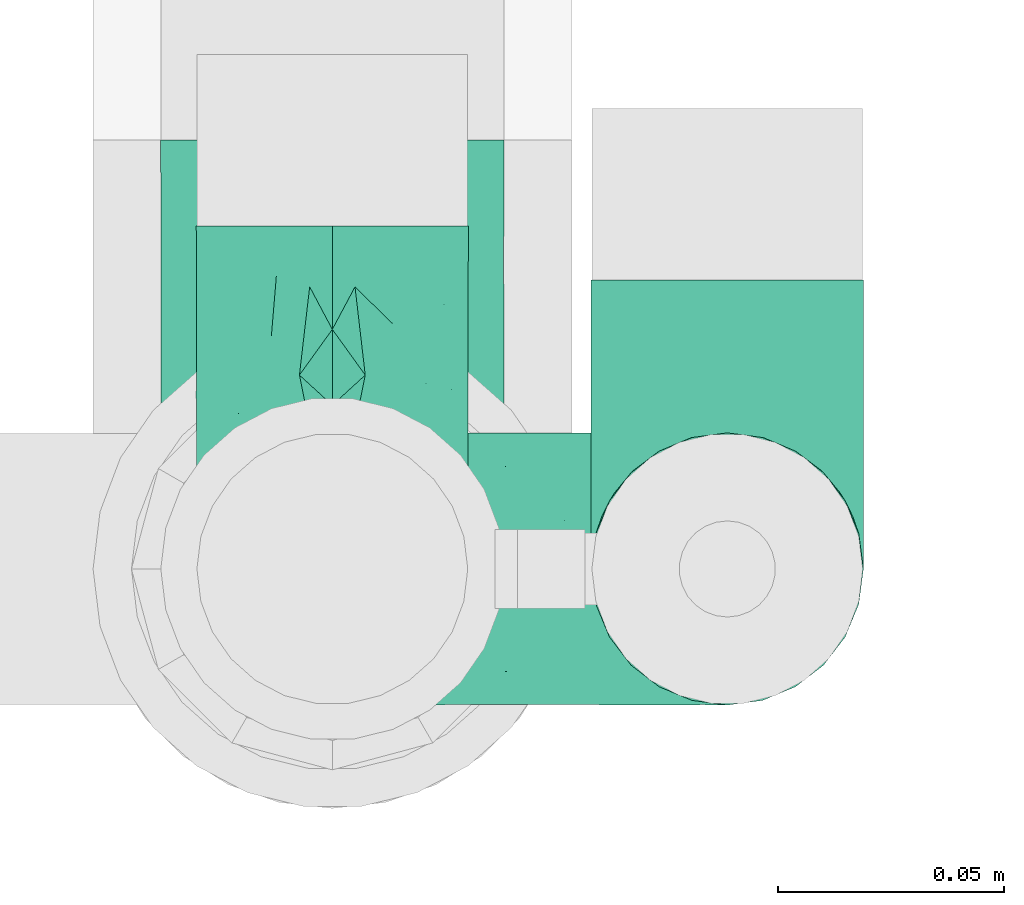
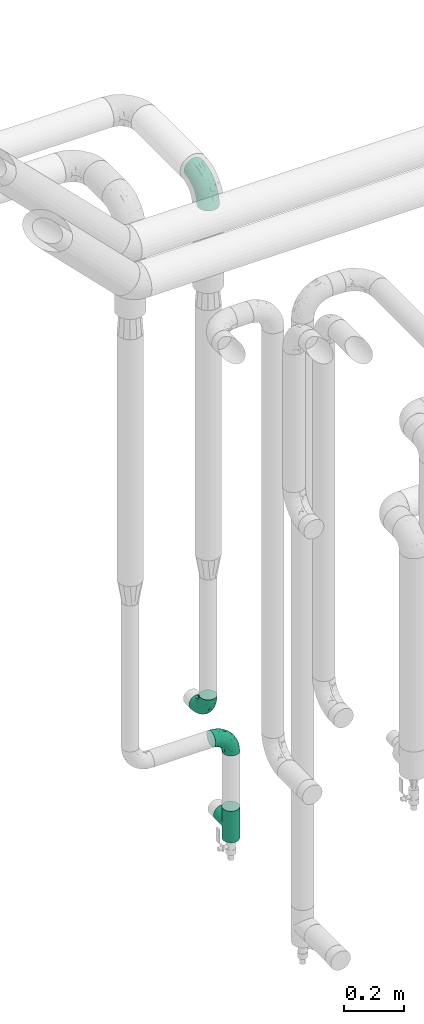
# One storey, part 682 of 824: 4 flow fittings.
"""IFC2X3 building model written with IfcOpenShell, lengths in millimetres."""

from ifc_helpers import new_model, entity, si_unit, converted_unit, derived_unit, direction, frame, origin, place, context, subcontext, project, spatial, faceted_brep, source, transform, mapped, material, type_object, type_shapes, element, save


model = new_model("IFC2X3")

# Units and contexts
model_context = context("Model", 3, precision=0.01, world=origin(), true_north=direction((6.12303176911189e-17, 1.0)))
body_context = subcontext(model_context, "Body", "Model", "MODEL_VIEW")
ifc_project = project(units=[si_unit("LENGTHUNIT", "METRE", prefix="MILLI"), si_unit("AREAUNIT", "SQUARE_METRE"), si_unit("VOLUMEUNIT", "CUBIC_METRE"), converted_unit("PLANEANGLEUNIT", "DEGREE", entity("IfcRatioMeasure", 0.0174532925199433), si_unit("PLANEANGLEUNIT", "RADIAN"), dimensions=[0, 0, 0, 0, 0, 0, 0]), si_unit("MASSUNIT", "GRAM", prefix="KILO"), derived_unit("MASSDENSITYUNIT", [(si_unit("MASSUNIT", "GRAM", prefix="KILO"), 1), (si_unit("LENGTHUNIT", "METRE"), -3)]), derived_unit("MOMENTOFINERTIAUNIT", [(si_unit("LENGTHUNIT", "METRE"), 4)]), si_unit("TIMEUNIT", "SECOND"), si_unit("FREQUENCYUNIT", "HERTZ"), si_unit("THERMODYNAMICTEMPERATUREUNIT", "DEGREE_CELSIUS"), derived_unit("THERMALTRANSMITTANCEUNIT", [(si_unit("MASSUNIT", "GRAM", prefix="KILO"), 1), (si_unit("THERMODYNAMICTEMPERATUREUNIT", "KELVIN"), -1), (si_unit("TIMEUNIT", "SECOND"), -3)]), derived_unit("VOLUMETRICFLOWRATEUNIT", [(si_unit("LENGTHUNIT", "METRE"), 3), (si_unit("TIMEUNIT", "SECOND"), -1)]), derived_unit("MASSFLOWRATEUNIT", [(si_unit("MASSUNIT", "GRAM", prefix="KILO"), 1), (si_unit("TIMEUNIT", "SECOND"), -1)]), derived_unit("ROTATIONALFREQUENCYUNIT", [(si_unit("TIMEUNIT", "SECOND"), -1)]), si_unit("ELECTRICCURRENTUNIT", "AMPERE"), si_unit("ELECTRICVOLTAGEUNIT", "VOLT"), si_unit("POWERUNIT", "WATT"), si_unit("FORCEUNIT", "NEWTON", prefix="KILO"), si_unit("ILLUMINANCEUNIT", "LUX"), si_unit("LUMINOUSFLUXUNIT", "LUMEN"), si_unit("LUMINOUSINTENSITYUNIT", "CANDELA"), derived_unit("USERDEFINED", [(si_unit("MASSUNIT", "GRAM", prefix="KILO"), -1), (si_unit("LENGTHUNIT", "METRE"), -2), (si_unit("TIMEUNIT", "SECOND"), 3), (si_unit("LUMINOUSFLUXUNIT", "LUMEN"), 1)]), derived_unit("LINEARVELOCITYUNIT", [(si_unit("LENGTHUNIT", "METRE"), 1), (si_unit("TIMEUNIT", "SECOND"), -1)]), si_unit("PRESSUREUNIT", "PASCAL"), derived_unit("USERDEFINED", [(si_unit("LENGTHUNIT", "METRE"), -2), (si_unit("MASSUNIT", "GRAM", prefix="KILO"), 1), (si_unit("TIMEUNIT", "SECOND"), -2)]), derived_unit("LINEARFORCEUNIT", [(si_unit("MASSUNIT", "GRAM", prefix="KILO"), 1), (si_unit("LENGTHUNIT", "METRE"), 1), (si_unit("TIMEUNIT", "SECOND"), -2), (si_unit("LENGTHUNIT", "METRE"), -1)]), derived_unit("PLANARFORCEUNIT", [(si_unit("MASSUNIT", "GRAM", prefix="KILO"), 1), (si_unit("LENGTHUNIT", "METRE"), 1), (si_unit("TIMEUNIT", "SECOND"), -2), (si_unit("LENGTHUNIT", "METRE"), -2)])], contexts=[model_context])

# Site, building, storey
site_placement = place(None, origin())
site = spatial("IfcSite", under=ifc_project, at=site_placement, CompositionType="ELEMENT")
building_placement = place(site_placement, origin())
building = spatial("IfcBuilding", under=site, at=building_placement, CompositionType="ELEMENT")
storey_placement = place(building_placement, frame((0.0, 0.0, 28200.0)))
storey = spatial("IfcBuildingStorey", under=building, at=storey_placement, CompositionType="ELEMENT", Elevation=28200.0)

# Flow fittings
ifc_material = material()
pipe_fitting_type_1 = type_object("IfcPipeFittingType", PredefinedType="NOTDEFINED", material=ifc_material)
shared_shape_1 = source(origin(), body_context, "Body", "Brep", [
    faceted_brep([(-76.0, 15.07, -26.11), (-76.0, 7.8, -29.12), (-76.0, 0.0, -30.15), (-76.0, -7.8, -29.12), (-76.0, -15.08, -26.11), (-76.0, -21.32, -21.32), (-76.0, -26.11, -15.08), (-76.0, -29.12, -7.8), (-76.0, -30.15, 0.0), (-76.0, -29.12, 7.8), (-76.0, -26.11, 15.07), (-76.0, -21.32, 21.32), (-76.0, -15.08, 26.11), (-76.0, -7.8, 29.12), (-76.0, 0.0, 30.15), (-76.0, 7.8, 29.12), (-76.0, 15.07, 26.11), (-76.0, 21.32, 21.32), (-76.0, 26.11, 15.07), (-76.0, 29.12, 7.8), (-76.0, 30.15, 0.0), (-76.0, 29.12, -7.8), (-76.0, 26.11, -15.08), (-76.0, 21.32, -21.32), (0.0, 76.0, -30.15), (-7.8, 76.0, -29.12), (-15.07, 76.0, -26.11), (-21.32, 76.0, -21.32), (-26.11, 76.0, -15.08), (-29.12, 76.0, -7.8), (-30.15, 76.0, 0.0), (-29.12, 76.0, 7.8), (-26.11, 76.0, 15.07), (-21.32, 76.0, 21.32), (-15.07, 76.0, 26.11), (-7.8, 76.0, 29.12), (0.0, 76.0, 30.15), (7.8, 76.0, 29.12), (15.08, 76.0, 26.11), (21.32, 76.0, 21.32), (26.11, 76.0, 15.07), (29.12, 76.0, 7.8), (30.15, 76.0, 0.0), (29.12, 76.0, -7.8), (26.11, 76.0, -15.08), (21.32, 76.0, -21.32), (15.08, 76.0, -26.11), (7.8, 76.0, -29.12), (10.79, 31.43, 21.07), (4.32, 31.7, 25.72), (1.65, 15.19, 19.92), (-61.17, -27.8, 0.0), (-51.1, -25.49, 9.84), (-56.14, -10.61, 27.27), (-31.7, -4.32, 25.72), (-39.75, 1.72, 29.41), (-43.2, -24.95, 0.0), (-1.86, 1.86, 0.0), (4.49, 7.65, 5.78), (-7.82, -4.61, 5.83), (-56.21, -22.79, 17.21), (-58.98, -3.38, 29.7), (-53.96, 5.6, 30.07), (-10.86, 10.86, 25.48), (-17.2, -2.6, 20.44), (-49.15, -16.01, 22.7), (-22.18, -14.24, 7.99), (-28.4, -17.42, 0.0), (-13.61, -9.88, 0.0), (-39.0, 23.48, 27.76), (-58.76, 12.54, 28.36), (-41.61, 15.41, 29.48), (16.01, 49.15, 22.7), (-58.55, 25.93, 19.53), (-51.53, 33.5, 13.51), (-64.92, 28.76, 12.4), (-7.48, 23.14, 28.25), (-1.72, 39.75, 29.41), (-12.04, 27.88, 29.88), (-63.91, 18.81, 24.52), (-11.63, 65.16, 28.18), (-4.97, 57.02, 30.05), (9.88, 13.61, 0.0), (-62.5, 31.74, 5.02), (-45.17, 30.98, 21.2), (-21.78, 9.76, 28.58), (10.61, 56.14, 27.27), (-32.09, 54.42, 13.26), (22.79, 56.21, 17.21), (15.38, 31.17, 15.63), (25.49, 51.1, 9.84), (21.84, 36.35, 5.92), (24.95, 43.2, 0.0), (3.38, 58.98, 29.7), (-31.17, -15.38, 15.63), (-39.39, 41.78, 15.45), (-34.56, 41.13, 20.79), (-39.81, -23.25, 5.49), (27.8, 61.17, 0.0), (-31.74, 62.5, 5.02), (-53.07, 36.29, 0.0), (-42.95, 42.95, 7.29), (-36.29, 53.07, 0.0), (-19.83, 58.51, 24.79), (-25.48, 60.2, 19.41), (-14.53, 50.96, 28.57), (-13.31, 37.09, 30.07), (-26.16, 40.06, 26.4), (-32.43, -10.35, 21.9), (17.42, 28.4, 0.0), (14.24, 22.18, 7.99), (-38.67, 9.72, 30.15), (-24.66, 17.36, 30.09), (-37.08, 31.49, 24.99), (-49.27, 22.83, 25.24), (-20.8, 38.81, 28.63), (-27.58, 27.58, 29.2), (-36.07, -20.23, 10.71), (-15.19, -6.16, 14.9), (6.6, 15.4, 14.49), (-2.51, 2.51, 11.35), (-65.16, 11.63, -28.18), (-49.15, -16.01, -22.7), (-57.02, 4.97, -30.05), (-25.93, 58.55, -19.53), (-33.5, 51.53, -13.51), (-28.76, 64.92, -12.4), (-60.2, 25.48, -19.41), (-58.51, 19.83, -24.79), (4.61, 7.82, -5.83), (-7.65, -4.49, -5.78), (-2.51, 2.51, -11.35), (-62.5, 31.74, -5.02), (-50.96, 14.53, -28.57), (-37.09, 13.31, -30.07), (-42.95, 42.95, -7.29), (25.49, 51.1, -9.84), (22.79, 56.21, -17.21), (-40.06, 26.16, -26.4), (3.38, 58.98, -29.7), (-5.6, 53.96, -30.07), (-27.88, 12.04, -29.88), (-9.76, 21.78, -28.58), (-23.14, 7.48, -28.25), (-51.1, -25.49, -9.84), (15.38, 31.17, -15.63), (16.01, 49.15, -22.7), (-23.48, 39.0, -27.76), (-12.54, 58.76, -28.36), (-15.41, 41.61, -29.48), (-56.21, -22.79, -17.21), (-9.72, 38.67, -30.15), (-17.36, 24.66, -30.09), (-22.18, -14.24, -7.99), (-41.13, 34.56, -20.79), (-31.74, 62.5, -5.02), (-58.98, -3.38, -29.7), (-31.17, -15.38, -15.63), (-56.14, -10.61, -27.27), (14.24, 22.18, -7.99), (23.25, 39.81, -5.49), (-31.49, 37.08, -24.99), (-15.19, -6.16, -14.9), (1.65, 15.19, -19.92), (-18.81, 63.91, -24.52), (-32.59, -11.62, -20.84), (-31.7, -4.32, -25.72), (-17.2, -2.6, -20.44), (-39.75, 1.72, -29.41), (-54.42, 32.09, -13.26), (-30.98, 45.17, -21.2), (10.61, 56.14, -27.27), (10.23, 31.31, -21.52), (4.32, 31.7, -25.72), (-41.78, 39.39, -15.45), (-1.72, 39.75, -29.41), (-36.35, -21.84, -5.92), (-22.83, 49.27, -25.24), (-38.81, 20.8, -28.63), (-27.58, 27.58, -29.2), (-10.86, 10.86, -25.48), (20.23, 36.07, -10.71), (6.6, 15.4, -14.49)], [[[0, 1, 2, 3, 4, 5, 6, 7, 8, 9, 10, 11, 12, 13, 14, 15, 16, 17, 18, 19, 20, 21, 22, 23]], [[24, 25, 26, 27, 28, 29, 30, 31, 32, 33, 34, 35, 36, 37, 38, 39, 40, 41, 42, 43, 44, 45, 46, 47]], [[48, 49, 50]], [[51, 52, 9]], [[53, 54, 55]], [[9, 52, 10]], [[56, 52, 51]], [[57, 58, 59]], [[11, 10, 60]], [[14, 61, 62]], [[63, 54, 64]], [[65, 12, 11]], [[65, 53, 12]], [[66, 67, 68]], [[69, 70, 71]], [[72, 39, 38]], [[73, 74, 75]], [[15, 70, 16]], [[76, 77, 78]], [[16, 79, 17]], [[13, 61, 14]], [[35, 80, 81]], [[14, 62, 15]], [[17, 73, 18]], [[57, 82, 58]], [[20, 19, 83]], [[75, 19, 18]], [[70, 15, 62]], [[73, 84, 74]], [[78, 85, 76]], [[38, 86, 72]], [[32, 31, 87]], [[88, 89, 90]], [[91, 92, 90]], [[72, 86, 49]], [[36, 93, 37]], [[75, 83, 19]], [[36, 35, 81]], [[60, 94, 65]], [[40, 90, 41]], [[95, 96, 87]], [[88, 90, 40]], [[66, 97, 67]], [[90, 98, 41]], [[40, 39, 88]], [[99, 31, 30]], [[20, 83, 100]], [[101, 102, 100]], [[52, 60, 10]], [[102, 99, 30]], [[96, 103, 104]], [[83, 101, 100]], [[12, 53, 13]], [[104, 103, 33]], [[105, 106, 81]], [[107, 105, 103]], [[64, 54, 108]], [[80, 103, 105]], [[80, 35, 34]], [[34, 33, 103]], [[86, 38, 37]], [[109, 110, 82]], [[71, 111, 112]], [[69, 107, 113]], [[79, 73, 17]], [[114, 113, 84]], [[33, 32, 104]], [[115, 107, 116]], [[105, 115, 106]], [[93, 81, 77]], [[54, 53, 65]], [[61, 53, 55]], [[108, 94, 64]], [[54, 63, 85]], [[93, 86, 37]], [[77, 76, 49]], [[77, 49, 86]], [[49, 63, 50]], [[60, 52, 117]], [[65, 11, 60]], [[39, 72, 88]], [[89, 88, 72]], [[71, 70, 62]], [[79, 70, 114]], [[103, 96, 107]], [[69, 113, 114]], [[112, 106, 116]], [[77, 81, 106]], [[112, 116, 71]], [[112, 55, 85]], [[64, 50, 63]], [[57, 59, 68]], [[32, 87, 104]], [[96, 104, 87]], [[94, 118, 64]], [[50, 119, 89]], [[50, 64, 118]], [[50, 89, 48]], [[81, 93, 36]], [[86, 93, 77]], [[53, 61, 13]], [[62, 61, 55]], [[71, 62, 111]], [[69, 71, 116]], [[95, 101, 74]], [[99, 101, 87]], [[118, 66, 59]], [[117, 97, 66]], [[117, 66, 94]], [[91, 89, 110]], [[91, 110, 109]], [[110, 89, 119]], [[9, 8, 51]], [[98, 90, 92]], [[98, 42, 41]], [[101, 83, 74]], [[101, 99, 102]], [[87, 31, 99]], [[62, 55, 111]], [[55, 112, 111]], [[107, 69, 116]], [[70, 69, 114]], [[107, 96, 113]], [[84, 113, 96]], [[84, 96, 95]], [[114, 84, 73]], [[70, 79, 16]], [[73, 79, 114]], [[54, 85, 55]], [[76, 85, 63]], [[49, 76, 63]], [[77, 106, 78]], [[106, 112, 78]], [[85, 78, 112]], [[73, 75, 18]], [[83, 75, 74]], [[103, 80, 34]], [[81, 80, 105]], [[101, 95, 87]], [[84, 95, 74]], [[106, 115, 116]], [[105, 107, 115]], [[120, 59, 58]], [[82, 110, 58]], [[119, 58, 110]], [[118, 59, 120]], [[66, 68, 59]], [[54, 65, 108]], [[94, 108, 65]], [[66, 118, 94]], [[50, 118, 120]], [[50, 120, 119]], [[119, 120, 58]], [[89, 72, 48]], [[49, 48, 72]], [[60, 117, 94]], [[117, 52, 97]], [[52, 56, 97]], [[67, 97, 56]], [[92, 91, 109]], [[89, 91, 90]], [[121, 1, 0]], [[122, 5, 4]], [[2, 1, 123]], [[124, 125, 126]], [[127, 128, 23]], [[129, 130, 131]], [[100, 132, 20]], [[133, 134, 123]], [[135, 100, 102]], [[136, 137, 44]], [[133, 128, 138]], [[24, 139, 140]], [[141, 142, 143]], [[121, 128, 133]], [[6, 144, 7]], [[137, 145, 146]], [[144, 51, 7]], [[147, 148, 149]], [[144, 6, 150]], [[149, 151, 152]], [[153, 68, 67]], [[154, 128, 127]], [[30, 155, 102]], [[43, 42, 98]], [[156, 3, 2]], [[157, 144, 150]], [[158, 4, 3]], [[24, 140, 25]], [[155, 135, 102]], [[159, 160, 109]], [[30, 29, 155]], [[147, 138, 161]], [[27, 124, 28]], [[57, 129, 82]], [[162, 163, 131]], [[27, 26, 164]], [[148, 26, 25]], [[165, 166, 167]], [[24, 47, 139]], [[143, 168, 141]], [[22, 21, 169]], [[125, 124, 170]], [[148, 25, 140]], [[46, 146, 171]], [[158, 122, 4]], [[0, 23, 128]], [[1, 121, 123]], [[109, 82, 159]], [[45, 44, 137]], [[146, 46, 45]], [[136, 43, 98]], [[132, 21, 20]], [[136, 98, 92]], [[172, 173, 146]], [[46, 171, 47]], [[43, 136, 44]], [[174, 154, 169]], [[171, 173, 175]], [[6, 5, 150]], [[126, 29, 28]], [[176, 56, 144]], [[122, 158, 166]], [[164, 124, 27]], [[177, 161, 170]], [[23, 22, 127]], [[178, 138, 179]], [[133, 178, 134]], [[156, 123, 168]], [[156, 158, 3]], [[168, 143, 166]], [[168, 166, 158]], [[166, 180, 167]], [[173, 171, 146]], [[139, 171, 175]], [[172, 145, 163]], [[173, 180, 142]], [[5, 122, 150]], [[157, 150, 122]], [[137, 136, 181]], [[146, 45, 137]], [[149, 148, 140]], [[164, 148, 177]], [[128, 154, 138]], [[147, 161, 177]], [[152, 134, 179]], [[168, 123, 134]], [[152, 179, 149]], [[152, 175, 142]], [[57, 130, 129]], [[157, 165, 167]], [[22, 169, 127]], [[154, 127, 169]], [[163, 167, 180]], [[162, 157, 167]], [[173, 163, 180]], [[182, 163, 145]], [[123, 156, 2]], [[158, 156, 168]], [[171, 139, 47]], [[140, 139, 175]], [[149, 140, 151]], [[147, 149, 179]], [[174, 135, 125]], [[132, 135, 169]], [[176, 157, 153]], [[176, 153, 67]], [[153, 157, 162]], [[182, 159, 129]], [[181, 160, 159]], [[181, 159, 145]], [[51, 144, 56]], [[51, 8, 7]], [[135, 132, 100]], [[169, 21, 132]], [[126, 155, 29]], [[135, 155, 125]], [[140, 175, 151]], [[175, 152, 151]], [[138, 147, 179]], [[148, 147, 177]], [[138, 154, 161]], [[170, 161, 154]], [[170, 154, 174]], [[177, 170, 124]], [[148, 164, 26]], [[124, 164, 177]], [[173, 142, 175]], [[143, 142, 180]], [[166, 143, 180]], [[168, 134, 141]], [[134, 152, 141]], [[142, 141, 152]], [[124, 126, 28]], [[155, 126, 125]], [[128, 121, 0]], [[123, 121, 133]], [[135, 174, 169]], [[170, 174, 125]], [[134, 178, 179]], [[133, 138, 178]], [[130, 153, 162]], [[68, 153, 130]], [[57, 68, 130]], [[182, 129, 131]], [[159, 82, 129]], [[157, 122, 165]], [[166, 165, 122]], [[163, 162, 167]], [[162, 131, 130]], [[145, 172, 146]], [[163, 173, 172]], [[159, 182, 145]], [[131, 163, 182]], [[56, 176, 67]], [[157, 176, 144]], [[137, 181, 145]], [[181, 136, 160]], [[136, 92, 160]], [[109, 160, 92]]]),
])
type_shapes(pipe_fitting_type_1, [shared_shape_1])
for number, where, z_axis, x_axis in (
    (1, (46807.82, 18991.22, 836.38), (1.0, 0.0, 0.0), (0.0, 0.0, -1.0)),
    (2, (46895.32, 18991.22, 730.0), (0.0, 1.0, 0.0), (1.0, 0.0, 0.0)),
):
    element("IfcFlowFitting", number, at=place(storey_placement, frame(where, z_axis=z_axis, x_axis=x_axis)), inside=storey, type_object=pipe_fitting_type_1, material=ifc_material, context=body_context, shape_type="MappedRepresentation", body=[
        mapped(shared_shape_1, transform((0.0, 0.0, 0.0), scale=1.0)),
    ])
pipe_fitting_type_2 = type_object("IfcPipeFittingType", PredefinedType="NOTDEFINED", material=ifc_material)
shared_shape_2 = source(origin(), body_context, "Body", "Brep", [
    faceted_brep([(-95.0, 19.02, -32.95), (-95.0, 9.85, -36.75), (-95.0, 0.0, -38.05), (-95.0, -9.85, -36.75), (-95.0, -19.03, -32.95), (-95.0, -26.91, -26.91), (-95.0, -32.95, -19.03), (-95.0, -36.75, -9.85), (-95.0, -38.05, 0.0), (-95.0, -36.75, 9.85), (-95.0, -32.95, 19.02), (-95.0, -26.91, 26.91), (-95.0, -19.03, 32.95), (-95.0, -9.85, 36.75), (-95.0, 0.0, 38.05), (-95.0, 9.85, 36.75), (-95.0, 19.02, 32.95), (-95.0, 26.91, 26.91), (-95.0, 32.95, 19.02), (-95.0, 36.75, 9.85), (-95.0, 38.05, 0.0), (-95.0, 36.75, -9.85), (-95.0, 32.95, -19.03), (-95.0, 26.91, -26.91), (0.0, 95.0, -38.05), (-9.85, 95.0, -36.75), (-19.02, 95.0, -32.95), (-26.91, 95.0, -26.91), (-32.95, 95.0, -19.03), (-36.75, 95.0, -9.85), (-38.05, 95.0, 0.0), (-36.75, 95.0, 9.85), (-32.95, 95.0, 19.02), (-26.91, 95.0, 26.91), (-19.02, 95.0, 32.95), (-9.85, 95.0, 36.75), (0.0, 95.0, 38.05), (9.85, 95.0, 36.75), (19.03, 95.0, 32.95), (26.91, 95.0, 26.91), (32.95, 95.0, 19.02), (36.75, 95.0, 9.85), (38.05, 95.0, 0.0), (36.75, 95.0, -9.85), (32.95, 95.0, -19.03), (26.91, 95.0, -26.91), (19.03, 95.0, -32.95), (9.85, 95.0, -36.75), (-7.99, -4.96, 6.3), (-0.92, 0.92, 0.0), (4.62, 8.1, 8.01), (-76.19, -35.57, 0.0), (-64.32, -32.32, 12.43), (20.51, 62.45, 28.68), (-60.56, -33.52, 0.0), (-70.4, -13.47, 34.42), (-39.61, -5.88, 32.32), (-49.6, 2.07, 37.1), (-70.34, -28.81, 21.71), (14.64, 40.81, 26.5), (5.88, 39.61, 32.32), (3.59, 20.77, 25.31), (-40.45, 68.06, 16.75), (-62.45, -20.51, 28.68), (-44.52, -26.87, 0.0), (-28.47, -20.22, 0.0), (-26.43, -17.83, 8.75), (-76.1, 39.63, 10.76), (-72.74, 37.58, 18.19), (-60.35, 46.18, 14.61), (-13.4, 13.4, 32.12), (-20.77, -3.59, 25.31), (-14.66, 81.47, 35.56), (-6.22, 71.26, 37.92), (-57.5, 42.48, 22.79), (-15.0, 34.74, 37.7), (-27.1, 12.08, 36.05), (-9.2, 28.81, 35.63), (-79.98, 23.7, 30.95), (-73.68, -4.3, 37.48), (-30.74, 21.67, 37.97), (-62.36, 47.59, 6.79), (-72.71, 32.83, 24.69), (-67.42, 7.02, 37.95), (-32.13, 75.27, 24.51), (-43.46, 51.47, 26.26), (-24.98, 73.15, 31.29), (20.59, 41.28, 19.85), (7.79, 16.09, 15.86), (-73.21, 42.39, 0.0), (-54.73, 54.73, 0.0), (-73.44, 15.79, 35.79), (-5.94, 4.32, 20.43), (28.81, 70.34, 21.71), (32.32, 64.32, 12.43), (-53.59, 26.2, 35.09), (-52.02, 19.31, 37.21), (21.38, 33.53, 10.34), (26.87, 44.52, 0.0), (-48.28, 12.14, 38.05), (4.3, 73.68, 37.48), (-44.08, -25.52, 12.79), (-41.28, -20.59, 19.85), (35.57, 76.19, 0.0), (-47.26, 54.3, 20.18), (-47.4, 61.99, 8.58), (-42.39, 73.21, 0.0), (-39.67, 78.86, 7.21), (-45.69, 36.84, 33.11), (-32.83, 50.13, 33.35), (13.47, 70.4, 34.42), (-18.25, 63.73, 36.07), (-40.63, -13.75, 27.22), (-16.63, 46.37, 37.95), (-53.47, 38.79, 28.59), (-26.07, 48.54, 36.15), (-34.51, 34.51, 36.86), (-2.07, 49.6, 37.1), (-22.79, -10.49, 19.23), (-61.73, 28.67, 31.87), (9.65, 14.7, 0.0), (20.22, 28.47, 0.0), (33.52, 60.56, 0.0), (-11.42, -5.44, 13.25), (-14.7, -9.65, 0.0), (-81.47, 14.66, -35.56), (-62.45, -20.51, -28.68), (-71.26, 6.22, -37.92), (-75.27, 32.13, -24.51), (-73.15, 24.98, -31.29), (13.47, 70.4, -34.42), (5.88, 39.61, -32.32), (-2.07, 49.6, -37.1), (-78.86, 39.67, -7.21), (-70.4, -13.47, -34.42), (-39.61, -5.88, -32.32), (-61.99, 47.4, -8.58), (32.32, 64.32, -12.43), (28.81, 70.34, -21.71), (-63.73, 18.25, -36.07), (-50.13, 32.83, -33.35), (4.3, 73.68, -37.48), (-7.02, 67.42, -37.95), (-39.63, 76.1, -10.76), (-46.18, 60.35, -14.61), (-47.59, 62.36, -6.79), (-64.32, -32.32, -12.43), (-26.2, 53.59, -35.09), (-15.79, 73.44, -35.79), (-19.31, 52.02, -37.21), (-37.58, 72.74, -18.19), (-70.34, -28.81, -21.71), (-42.48, 57.5, -22.79), (-38.79, 53.47, -28.59), (-51.47, 43.46, -26.26), (-32.83, 72.71, -24.69), (-46.37, 16.63, -37.95), (-73.68, -4.3, -37.48), (-41.28, -20.59, -19.85), (-44.08, -25.52, -12.79), (13.75, 40.63, -27.22), (20.51, 62.45, -28.68), (-68.06, 40.45, -16.75), (-54.3, 47.26, -20.18), (-12.14, 48.28, -38.05), (-21.67, 30.74, -37.97), (-36.84, 45.69, -33.11), (-11.42, -5.44, -13.25), (7.79, 16.09, -15.86), (4.62, 8.1, -8.01), (-23.7, 79.98, -30.95), (-26.43, -17.83, -8.75), (-7.99, -4.96, -6.3), (-40.81, -14.64, -26.5), (-20.77, -3.59, -25.31), (-34.74, 15.0, -37.7), (-12.08, 27.1, -36.05), (-28.81, 9.2, -35.63), (-22.79, -10.49, -19.23), (21.38, 33.53, -10.34), (20.59, 41.28, -19.85), (-48.54, 26.07, -36.15), (-49.6, 2.07, -37.1), (-13.4, 13.4, -32.12), (3.59, 20.77, -25.31), (-28.67, 61.73, -31.87), (-34.51, 34.51, -36.86), (-5.94, 4.32, -20.43)], [[[0, 1, 2, 3, 4, 5, 6, 7, 8, 9, 10, 11, 12, 13, 14, 15, 16, 17, 18, 19, 20, 21, 22, 23]], [[24, 25, 26, 27, 28, 29, 30, 31, 32, 33, 34, 35, 36, 37, 38, 39, 40, 41, 42, 43, 44, 45, 46, 47]], [[48, 49, 50]], [[51, 52, 9]], [[53, 39, 38]], [[9, 52, 10]], [[54, 52, 51]], [[55, 56, 57]], [[11, 10, 58]], [[59, 60, 61]], [[32, 31, 62]], [[63, 12, 11]], [[63, 55, 12]], [[64, 65, 66]], [[67, 68, 69]], [[70, 56, 71]], [[35, 72, 73]], [[69, 68, 74]], [[75, 76, 77]], [[16, 78, 17]], [[13, 79, 14]], [[76, 75, 80]], [[67, 69, 81]], [[18, 17, 82]], [[14, 79, 83]], [[20, 19, 67]], [[84, 85, 86]], [[87, 61, 88]], [[89, 81, 90]], [[18, 82, 68]], [[15, 91, 16]], [[14, 83, 15]], [[71, 92, 61]], [[17, 78, 82]], [[93, 87, 94]], [[95, 91, 96]], [[97, 98, 94]], [[86, 72, 34]], [[96, 99, 80]], [[37, 36, 100]], [[40, 39, 93]], [[40, 94, 41]], [[64, 66, 101]], [[93, 94, 40]], [[58, 102, 63]], [[94, 103, 41]], [[94, 87, 97]], [[104, 69, 74]], [[34, 33, 86]], [[105, 69, 104]], [[52, 58, 10]], [[106, 107, 30]], [[108, 109, 85]], [[105, 106, 90]], [[53, 110, 60]], [[86, 111, 72]], [[86, 109, 111]], [[33, 84, 86]], [[12, 55, 13]], [[112, 56, 63]], [[110, 38, 37]], [[34, 72, 35]], [[36, 35, 73]], [[111, 113, 73]], [[105, 107, 106]], [[110, 53, 38]], [[74, 114, 85]], [[91, 15, 83]], [[105, 90, 81]], [[107, 62, 31]], [[33, 32, 84]], [[115, 109, 116]], [[111, 115, 113]], [[100, 73, 117]], [[56, 55, 63]], [[79, 55, 57]], [[102, 118, 112]], [[56, 70, 76]], [[100, 110, 37]], [[117, 77, 60]], [[117, 60, 110]], [[60, 70, 61]], [[58, 52, 101]], [[63, 11, 58]], [[39, 53, 93]], [[87, 93, 53]], [[96, 91, 83]], [[78, 91, 119]], [[32, 62, 84]], [[84, 62, 104]], [[86, 85, 109]], [[85, 114, 108]], [[80, 113, 116]], [[117, 73, 113]], [[80, 116, 96]], [[80, 57, 76]], [[71, 112, 118]], [[61, 87, 59]], [[62, 107, 105]], [[97, 120, 121]], [[70, 71, 61]], [[71, 118, 92]], [[73, 100, 36]], [[110, 100, 117]], [[55, 79, 13]], [[83, 79, 57]], [[96, 83, 99]], [[116, 108, 95]], [[50, 97, 88]], [[97, 87, 88]], [[50, 49, 120]], [[122, 94, 98]], [[89, 20, 67]], [[105, 81, 69]], [[89, 67, 81]], [[68, 19, 18]], [[68, 67, 19]], [[74, 68, 82]], [[114, 82, 119]], [[74, 85, 104]], [[82, 114, 74]], [[114, 119, 108]], [[95, 108, 119]], [[116, 109, 108]], [[123, 48, 50]], [[97, 50, 120]], [[123, 50, 88]], [[91, 95, 119]], [[116, 95, 96]], [[84, 104, 85]], [[104, 62, 105]], [[83, 57, 99]], [[57, 80, 99]], [[66, 48, 123]], [[66, 124, 48]], [[118, 66, 123]], [[124, 66, 65]], [[66, 118, 101]], [[54, 64, 52]], [[124, 49, 48]], [[30, 107, 31]], [[91, 78, 16]], [[82, 78, 119]], [[56, 76, 57]], [[77, 76, 70]], [[60, 77, 70]], [[77, 117, 75]], [[117, 113, 75]], [[113, 80, 75]], [[9, 8, 51]], [[103, 94, 122]], [[103, 42, 41]], [[73, 72, 111]], [[113, 115, 116]], [[111, 109, 115]], [[102, 112, 63]], [[71, 56, 112]], [[118, 102, 101]], [[92, 123, 88]], [[123, 92, 118]], [[61, 92, 88]], [[87, 53, 59]], [[60, 59, 53]], [[97, 121, 98]], [[58, 101, 102]], [[64, 101, 52]], [[125, 1, 0]], [[126, 5, 4]], [[2, 1, 127]], [[1, 125, 127]], [[128, 129, 23]], [[130, 131, 132]], [[89, 133, 20]], [[126, 134, 135]], [[136, 89, 90]], [[137, 138, 44]], [[139, 129, 140]], [[24, 141, 142]], [[143, 144, 145]], [[125, 129, 139]], [[6, 146, 7]], [[147, 148, 149]], [[146, 51, 7]], [[143, 150, 144]], [[146, 6, 151]], [[152, 153, 154]], [[126, 4, 134]], [[0, 23, 129]], [[28, 155, 150]], [[43, 42, 103]], [[54, 146, 64]], [[139, 156, 127]], [[157, 3, 2]], [[151, 158, 159]], [[160, 131, 161]], [[22, 21, 162]], [[136, 144, 163]], [[149, 164, 165]], [[24, 142, 25]], [[166, 140, 154]], [[154, 129, 128]], [[143, 30, 29]], [[167, 168, 169]], [[155, 28, 27]], [[26, 170, 27]], [[171, 167, 172]], [[26, 25, 148]], [[27, 170, 155]], [[173, 135, 174]], [[144, 150, 152]], [[175, 176, 177]], [[24, 47, 141]], [[45, 161, 46]], [[148, 25, 142]], [[176, 175, 165]], [[64, 159, 171]], [[138, 45, 44]], [[130, 46, 161]], [[137, 44, 43]], [[178, 159, 158]], [[137, 103, 122]], [[163, 144, 152]], [[136, 133, 89]], [[103, 137, 43]], [[6, 5, 151]], [[178, 158, 173]], [[134, 4, 3]], [[178, 173, 174]], [[137, 98, 179]], [[145, 90, 106]], [[138, 180, 161]], [[46, 130, 47]], [[136, 90, 145]], [[133, 162, 21]], [[23, 22, 128]], [[139, 140, 181]], [[139, 181, 156]], [[157, 127, 182]], [[157, 134, 3]], [[182, 177, 135]], [[182, 135, 134]], [[135, 183, 174]], [[131, 130, 161]], [[141, 130, 132]], [[160, 180, 184]], [[131, 183, 176]], [[5, 126, 151]], [[158, 151, 126]], [[180, 138, 137]], [[161, 45, 138]], [[149, 148, 142]], [[170, 148, 185]], [[22, 162, 128]], [[128, 162, 163]], [[129, 154, 140]], [[154, 153, 166]], [[165, 156, 186]], [[182, 127, 156]], [[165, 186, 149]], [[165, 132, 176]], [[131, 184, 183]], [[187, 167, 178]], [[184, 168, 187]], [[167, 169, 172]], [[184, 180, 168]], [[174, 183, 184]], [[127, 157, 2]], [[134, 157, 182]], [[130, 141, 47]], [[142, 141, 132]], [[149, 142, 164]], [[186, 166, 147]], [[180, 179, 168]], [[169, 179, 120]], [[137, 179, 180]], [[179, 121, 120]], [[106, 30, 143]], [[136, 145, 144]], [[106, 143, 145]], [[150, 29, 28]], [[150, 143, 29]], [[152, 150, 155]], [[153, 155, 185]], [[152, 154, 163]], [[155, 153, 152]], [[153, 185, 166]], [[147, 166, 185]], [[186, 140, 166]], [[169, 120, 49]], [[169, 49, 172]], [[179, 169, 168]], [[148, 147, 185]], [[186, 147, 149]], [[128, 163, 154]], [[163, 162, 136]], [[142, 132, 164]], [[132, 165, 164]], [[171, 124, 65]], [[124, 171, 172]], [[64, 146, 159]], [[171, 159, 178]], [[171, 65, 64]], [[172, 49, 124]], [[162, 133, 136]], [[20, 133, 21]], [[148, 170, 26]], [[155, 170, 185]], [[131, 176, 132]], [[177, 176, 183]], [[135, 177, 183]], [[177, 182, 175]], [[182, 156, 175]], [[156, 165, 175]], [[51, 146, 54]], [[51, 8, 7]], [[129, 125, 0]], [[127, 125, 139]], [[140, 186, 181]], [[156, 181, 186]], [[158, 126, 173]], [[135, 173, 126]], [[187, 178, 174]], [[171, 178, 167]], [[184, 187, 174]], [[167, 187, 168]], [[180, 160, 161]], [[184, 131, 160]], [[98, 137, 122]], [[98, 121, 179]], [[151, 159, 146]]]),
])
type_shapes(pipe_fitting_type_2, [shared_shape_2])
flow_fitting_1_placement = place(storey_placement, frame((46807.82, 18991.22, 3000.0), z_axis=(1.0, 0.0, 0.0), x_axis=(0.0, -1.0, 0.0)))
element("IfcFlowFitting", 3, at=flow_fitting_1_placement, inside=storey, type_object=pipe_fitting_type_2, material=ifc_material, context=body_context, shape_type="MappedRepresentation", body=[
    mapped(shared_shape_2, transform((0.0, 0.0, 0.0), scale=1.0)),
])
pipe_fitting_type_3 = type_object("IfcPipeFittingType", PredefinedType="NOTDEFINED", material=ifc_material)
shared_shape_3 = source(origin(), body_context, "Body", "Brep", [
    faceted_brep([(-64.0, 15.07, -26.11), (-64.0, 7.8, -29.12), (-64.0, 0.0, -30.15), (-64.0, -7.8, -29.12), (-64.0, -15.08, -26.11), (-64.0, -21.32, -21.32), (-64.0, -26.11, -15.08), (-64.0, -29.12, -7.8), (-64.0, -30.15, 0.0), (-64.0, -29.12, 7.8), (-64.0, -26.11, 15.07), (-64.0, -21.32, 21.32), (-64.0, -15.08, 26.11), (-64.0, -7.8, 29.12), (-64.0, 0.0, 30.15), (-64.0, 7.8, 29.12), (-64.0, 15.07, 26.11), (-64.0, 21.32, 21.32), (-64.0, 26.11, 15.07), (-64.0, 29.12, 7.8), (-64.0, 30.15, 0.0), (-64.0, 29.12, -7.8), (-64.0, 26.11, -15.08), (-64.0, 21.32, -21.32), (64.0, 0.0, -30.15), (64.0, 7.8, -29.12), (64.0, 15.07, -26.11), (64.0, 21.32, -21.32), (64.0, 26.11, -15.08), (64.0, 29.12, -7.8), (64.0, 30.15, 0.0), (64.0, 29.12, 7.8), (64.0, 26.11, 15.07), (64.0, 21.32, 21.32), (64.0, 15.07, 26.11), (64.0, 7.8, 29.12), (64.0, 0.0, 30.15), (64.0, -7.8, 29.12), (64.0, -15.08, 26.11), (64.0, -21.32, 21.32), (64.0, -26.11, 15.07), (64.0, -29.12, 7.8), (64.0, -30.15, 0.0), (64.0, -29.12, -7.8), (64.0, -26.11, -15.08), (64.0, -21.32, -21.32), (64.0, -15.08, -26.11), (64.0, -7.8, -29.12), (29.06, -29.06, 8.05), (30.15, -30.15, 0.0), (-30.15, -30.15, 0.0), (26.09, -26.09, 15.1), (16.9, -16.9, 24.97), (21.88, -21.88, 20.75), (-29.06, -29.06, 8.05), (-26.09, -26.09, 15.1), (-21.88, -21.88, 20.75), (-16.9, -16.9, 24.97), (-11.47, -11.47, 27.88), (11.47, -11.47, 27.88), (5.79, -5.79, 29.59), (0.0, 0.0, 30.15), (-5.79, -5.79, 29.59), (5.79, -5.79, -29.59), (0.0, 0.0, -30.15), (-5.79, -5.79, -29.59), (-11.47, -11.47, -27.88), (11.47, -11.47, -27.88), (16.9, -16.9, -24.97), (21.88, -21.88, -20.75), (26.09, -26.09, -15.1), (29.06, -29.06, -8.05), (-16.9, -16.9, -24.97), (-21.88, -21.88, -20.75), (-29.06, -29.06, -8.05), (-26.09, -26.09, -15.1), (0.0, -64.0, -30.15), (7.8, -64.0, -29.12), (15.08, -64.0, -26.11), (21.32, -64.0, -21.32), (26.11, -64.0, -15.08), (29.12, -64.0, -7.8), (30.15, -64.0, 0.0), (29.12, -64.0, 7.8), (26.11, -64.0, 15.07), (21.32, -64.0, 21.32), (15.08, -64.0, 26.11), (7.8, -64.0, 29.12), (0.0, -64.0, 30.15), (-7.8, -64.0, 29.12), (-15.07, -64.0, 26.11), (-21.32, -64.0, 21.32), (-26.11, -64.0, 15.07), (-29.12, -64.0, 7.8), (-30.15, -64.0, 0.0), (-29.12, -64.0, -7.8), (-26.11, -64.0, -15.08), (-21.32, -64.0, -21.32), (-15.07, -64.0, -26.11), (-7.8, -64.0, -29.12)], [[[0, 1, 2, 3, 4, 5, 6, 7, 8, 9, 10, 11, 12, 13, 14, 15, 16, 17, 18, 19, 20, 21, 22, 23]], [[24, 25, 26, 27, 28, 29, 30, 31, 32, 33, 34, 35, 36, 37, 38, 39, 40, 41, 42, 43, 44, 45, 46, 47]], [[41, 40, 48]], [[42, 41, 49]], [[50, 9, 8]], [[49, 41, 48]], [[40, 51, 48]], [[39, 38, 52]], [[51, 40, 53]], [[52, 53, 39]], [[53, 40, 39]], [[50, 54, 9]], [[9, 54, 10]], [[54, 55, 10]], [[56, 57, 11]], [[11, 10, 56]], [[11, 57, 12]], [[56, 10, 55]], [[12, 57, 58]], [[52, 38, 59]], [[60, 36, 61]], [[62, 61, 14]], [[59, 37, 60]], [[37, 59, 38]], [[60, 37, 36]], [[61, 36, 35, 15, 14]], [[32, 31, 19, 18]], [[17, 16, 34, 33]], [[18, 17, 33, 32]], [[35, 34, 16, 15]], [[20, 19, 31, 30]], [[62, 13, 58]], [[13, 62, 14]], [[58, 13, 12]], [[27, 23, 22, 28]], [[22, 21, 29, 28]], [[0, 23, 27, 26]], [[20, 30, 29, 21]], [[24, 47, 63]], [[24, 64, 2, 1, 25]], [[64, 24, 63]], [[2, 64, 65]], [[26, 25, 1, 0]], [[65, 66, 3]], [[2, 65, 3]], [[66, 4, 3]], [[63, 47, 67]], [[46, 45, 68]], [[69, 68, 45]], [[44, 70, 69]], [[69, 45, 44]], [[46, 68, 67]], [[43, 42, 49]], [[7, 50, 8]], [[43, 71, 44]], [[71, 43, 49]], [[44, 71, 70]], [[72, 4, 66]], [[72, 5, 4]], [[5, 72, 73]], [[5, 73, 6]], [[74, 50, 7]], [[75, 74, 6]], [[74, 7, 6]], [[75, 6, 73]], [[46, 67, 47]], [[76, 77, 78, 79, 80, 81, 82, 83, 84, 85, 86, 87, 88, 89, 90, 91, 92, 93, 94, 95, 96, 97, 98, 99]], [[50, 94, 93]], [[54, 50, 93]], [[91, 90, 57]], [[56, 92, 91]], [[54, 93, 92]], [[58, 90, 89]], [[55, 54, 92]], [[56, 55, 92]], [[58, 57, 90]], [[88, 61, 62]], [[58, 89, 62]], [[56, 91, 57]], [[62, 89, 88]], [[60, 88, 87]], [[86, 59, 87]], [[84, 83, 48]], [[53, 85, 84]], [[52, 86, 85]], [[49, 83, 82]], [[59, 60, 87]], [[52, 59, 86]], [[49, 48, 83]], [[51, 53, 84]], [[48, 51, 84]], [[52, 85, 53]], [[88, 60, 61]], [[82, 81, 49]], [[71, 49, 81]], [[69, 80, 79]], [[79, 78, 68]], [[71, 81, 80]], [[67, 78, 77]], [[70, 71, 80]], [[69, 70, 80]], [[67, 68, 78]], [[76, 64, 63]], [[67, 77, 63]], [[69, 79, 68]], [[63, 77, 76]], [[65, 76, 99]], [[98, 66, 99]], [[96, 95, 74]], [[73, 97, 96]], [[72, 98, 97]], [[50, 95, 94]], [[66, 65, 99]], [[72, 66, 98]], [[50, 74, 95]], [[75, 73, 96]], [[74, 75, 96]], [[72, 97, 73]], [[76, 65, 64]]]),
])
type_shapes(pipe_fitting_type_3, [shared_shape_3])
flow_fitting_2_placement = place(storey_placement, frame((46895.32, 18991.22, 365.0), z_axis=(-1.0, 0.0, 0.0), x_axis=(0.0, 0.0, -1.0)))
element("IfcFlowFitting", 4, at=flow_fitting_2_placement, inside=storey, type_object=pipe_fitting_type_3, material=ifc_material, context=body_context, shape_type="MappedRepresentation", body=[
    mapped(shared_shape_3, transform((0.0, 0.0, 0.0), scale=1.0)),
])

save(model, "model.ifc")
